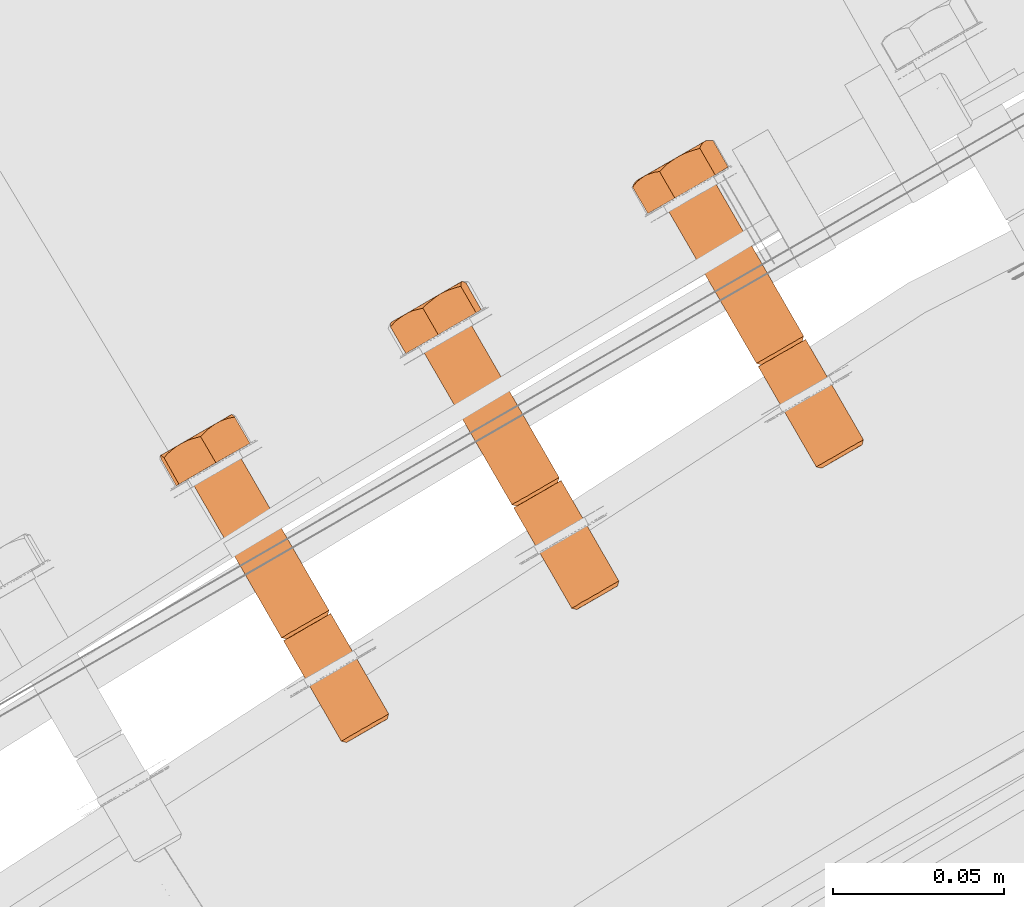
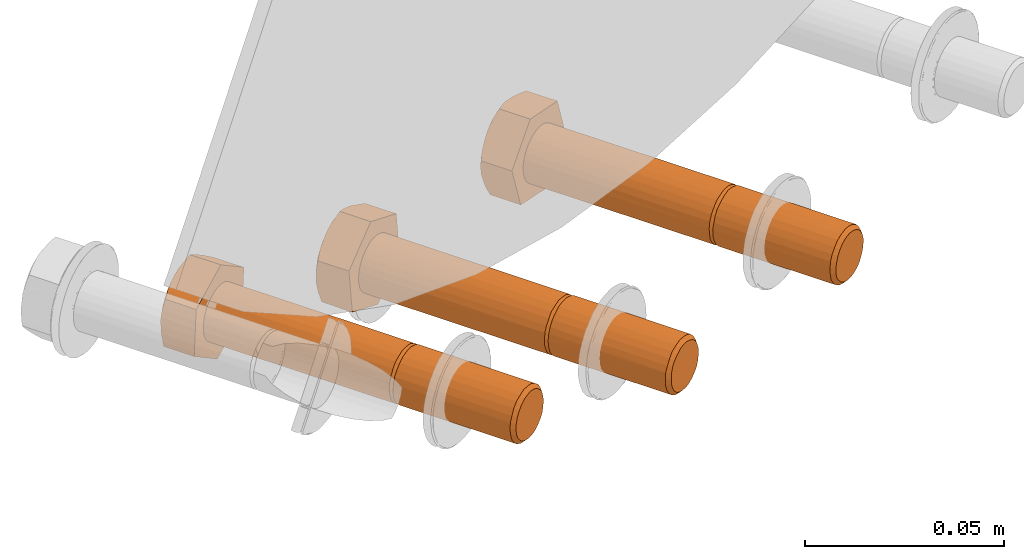
# One storey, part 75 of 126: 3 proxies.
"""IFC2X3 building model written with IfcOpenShell, lengths in millimetres."""

from ifc_helpers import new_model, si_unit, origin, origin_with_axes, place, context, project, spatial, faceted_brep, material, element, save


model = new_model("IFC2X3")

# Units and contexts
context_of_model_1 = context(None, 3, precision=0.1, world=origin())
context_of_model_2 = context(None, 3, precision=0.1, world=origin())
ifc_project = project(units=[si_unit("LENGTHUNIT", "METRE", prefix="MILLI"), si_unit("AREAUNIT", "SQUARE_METRE", prefix="CENTI"), si_unit("VOLUMEUNIT", "CUBIC_METRE", prefix="CENTI"), si_unit("MASSUNIT", "GRAM", prefix="KILO")], contexts=[context_of_model_1, context_of_model_2])

# Site, building, storey
site_placement = place(None, origin_with_axes())
site = spatial("IfcSite", under=ifc_project, at=site_placement, CompositionType="ELEMENT")
building_placement = place(site_placement, origin_with_axes())
building = spatial("IfcBuilding", under=site, at=building_placement, CompositionType="ELEMENT")
storey_placement = place(building_placement, origin_with_axes())
storey = spatial("IfcBuildingStorey", under=building, at=storey_placement, CompositionType="ELEMENT")

# Proxies
ifc_material = material(Name="STAHL")
proxy_1_placement = place(storey_placement, origin_with_axes())
element("IfcBuildingElementProxy", 1, at=proxy_1_placement, inside=storey, material=ifc_material, Name="profile", context=context_of_model_2, shape_type="Brep", body=[
    faceted_brep([(3989.7, 14868.7, 460.8), (3991.3, 14869.6, 460.2), (3992.0, 14868.8, 461.3), (3990.6, 14868.0, 461.8), (3988.3, 14867.9, 461.8), (3989.4, 14867.3, 462.7), (3987.1, 14867.2, 463.2), (3988.4, 14866.7, 463.9), (3986.2, 14866.7, 464.9), (3987.6, 14866.3, 465.3), (3985.8, 14866.4, 466.7), (3987.2, 14866.0, 466.9), (3985.7, 14866.4, 468.7), (3987.2, 14866.0, 468.6), (3986.0, 14866.6, 470.6), (3987.5, 14866.1, 470.2), (3986.7, 14867.0, 472.3), (3988.1, 14866.5, 471.7), (3987.8, 14867.6, 473.8), (3989.0, 14867.0, 473.0), (3989.1, 14868.4, 475.0), (3990.1, 14867.7, 474.0), (3990.6, 14869.2, 475.7), (3991.5, 14868.5, 474.7), (3992.3, 14870.2, 476.1), (3992.9, 14869.3, 475.0), (3994.0, 14871.2, 475.9), (3994.3, 14870.1, 474.9), (3972.2, 14899.0, 460.8), (3973.8, 14899.9, 460.2), (3974.5, 14899.1, 461.3), (3973.1, 14898.3, 461.8), (3970.8, 14898.2, 461.8), (3971.9, 14897.6, 462.7), (3969.6, 14897.5, 463.2), (3970.9, 14897.0, 463.9), (3968.7, 14897.0, 464.9), (3970.1, 14896.6, 465.3), (3968.3, 14896.7, 466.7), (3969.7, 14896.3, 466.9), (3968.2, 14896.7, 468.7), (3969.7, 14896.3, 468.6), (3968.5, 14896.9, 470.6), (3970.0, 14896.5, 470.2), (3969.2, 14897.3, 472.3), (3970.6, 14896.8, 471.7), (3970.3, 14897.9, 473.8), (3971.5, 14897.3, 473.0), (3971.6, 14898.7, 475.0), (3972.6, 14898.0, 474.0), (3973.1, 14899.5, 475.7), (3974.0, 14898.8, 474.7), (3974.8, 14900.5, 476.1), (3975.4, 14899.6, 475.0), (3976.5, 14901.5, 475.9), (3976.8, 14900.4, 474.9), (3995.5, 14872.1, 475.3), (3978.6, 14901.4, 475.3), (3977.0, 14900.5, 475.9), (3997.0, 14872.9, 474.3), (3980.0, 14902.3, 474.3), (3998.1, 14873.6, 472.9), (3981.2, 14902.9, 472.9), (3999.0, 14874.0, 471.2), (3982.0, 14903.4, 471.2), (3999.4, 14874.3, 469.4), (3982.5, 14903.7, 469.4), (3999.5, 14874.4, 467.5), (3982.6, 14903.7, 467.5), (3999.2, 14874.2, 465.6), (3982.2, 14903.5, 465.6), (3998.5, 14873.8, 463.8), (3981.5, 14903.1, 463.8), (3997.4, 14873.2, 462.3), (3980.5, 14902.5, 462.3), (3996.1, 14872.4, 461.2), (3979.1, 14901.8, 461.2), (3994.6, 14871.5, 460.4), (3977.6, 14900.9, 460.4), (3992.9, 14870.6, 460.1), (3976.0, 14899.9, 460.1), (3974.3, 14899.0, 460.2), (3947.8, 14947.2, 476.1), (3946.2, 14946.2, 475.7), (3949.5, 14948.2, 475.9), (3945.2, 14945.7, 460.8), (3946.8, 14946.6, 460.2), (3943.8, 14944.9, 461.8), (3942.6, 14944.2, 463.2), (3941.8, 14943.7, 464.9), (3941.3, 14943.4, 466.7), (3941.2, 14943.4, 468.7), (3941.6, 14943.6, 470.6), (3942.3, 14944.0, 472.3), (3943.3, 14944.6, 473.8), (3944.7, 14945.4, 475.0), (3978.0, 14902.4, 475.3), (3951.1, 14949.1, 475.3), (3979.5, 14903.2, 474.3), (3952.5, 14949.9, 474.3), (3980.6, 14903.9, 472.9), (3953.7, 14950.6, 472.9), (3981.5, 14904.4, 471.2), (3954.5, 14951.0, 471.2), (3981.9, 14904.6, 469.4), (3955.0, 14951.3, 469.4), (3982.0, 14904.7, 467.5), (3955.1, 14951.4, 467.5), (3981.7, 14904.5, 465.6), (3954.7, 14951.2, 465.6), (3981.0, 14904.1, 463.8), (3954.0, 14950.8, 463.8), (3979.9, 14903.5, 462.3), (3953.0, 14950.2, 462.3), (3978.6, 14902.7, 461.2), (3951.6, 14949.4, 461.2), (3977.1, 14901.8, 460.4), (3950.1, 14948.5, 460.4), (3975.4, 14900.9, 460.1), (3948.5, 14947.6, 460.1), (3936.4, 14940.6, 470.8), (3940.2, 14942.8, 457.7), (3952.0, 14949.6, 454.9), (3959.9, 14954.2, 465.4), (3956.1, 14951.9, 478.5), (3944.3, 14945.1, 481.2), (3955.5, 14961.9, 465.4), (3954.6, 14962.0, 467.3), (3953.9, 14962.0, 469.1), (3953.4, 14961.9, 470.5), (3953.0, 14961.7, 471.9), (3952.5, 14961.3, 473.7), (3952.1, 14960.8, 475.5), (3951.8, 14960.3, 477.0), (3951.6, 14959.7, 478.5), (3946.9, 14958.2, 479.3), (3947.9, 14958.5, 479.2), (3949.7, 14959.1, 478.9), (3952.3, 14961.3, 473.8), (3951.3, 14960.7, 475.6), (3950.0, 14960.0, 477.1), (3948.5, 14959.1, 478.3), (3946.5, 14957.9, 479.5), (3945.2, 14957.2, 479.8), (3951.0, 14960.5, 460.2), (3952.0, 14961.2, 461.8), (3952.8, 14961.6, 463.7), (3953.3, 14961.9, 465.7), (3953.5, 14962.0, 467.8), (3953.4, 14962.0, 469.9), (3954.3, 14961.7, 464.2), (3953.3, 14961.5, 463.0), (3952.1, 14961.1, 461.6), (3941.1, 14954.9, 456.3), (3942.9, 14955.9, 456.1), (3944.7, 14956.9, 456.2), (3946.5, 14958.0, 456.7), (3948.1, 14958.9, 457.5), (3949.7, 14959.8, 458.7), (3950.1, 14960.0, 459.0), (3949.3, 14959.4, 457.9), (3948.4, 14958.4, 456.4), (3947.5, 14957.3, 454.9), (3946.0, 14956.9, 455.3), (3944.5, 14956.4, 455.6), (3942.8, 14955.7, 455.9), (3943.6, 14956.2, 480.2), (3942.1, 14955.1, 480.6), (3941.0, 14954.0, 480.9), (3939.8, 14952.9, 481.2), (3938.4, 14952.7, 479.7), (3937.2, 14952.3, 478.3), (3936.2, 14952.0, 477.1), (3935.3, 14951.5, 476.0), (3934.3, 14950.8, 474.6), (3933.3, 14950.0, 473.1), (3932.6, 14949.2, 472.0), (3931.9, 14948.3, 470.8), (3933.3, 14950.4, 464.2), (3934.0, 14950.8, 462.3), (3935.0, 14951.4, 460.6), (3936.3, 14952.1, 459.0), (3937.8, 14952.9, 457.8), (3939.4, 14953.9, 456.9), (3939.9, 14954.1, 456.6), (3938.6, 14953.2, 456.9), (3937.2, 14951.9, 457.3), (3935.8, 14950.5, 457.7), (3935.1, 14950.6, 459.2), (3934.5, 14950.7, 460.6), (3933.9, 14950.6, 462.4), (3934.3, 14950.9, 474.3), (3933.5, 14950.4, 472.4), (3933.0, 14950.2, 470.4), (3932.8, 14950.0, 468.3), (3932.9, 14950.1, 466.2), (3932.9, 14950.1, 465.6), (3932.6, 14949.7, 467.1), (3932.2, 14949.1, 468.9), (3943.4, 14956.2, 480.1), (3941.6, 14955.1, 479.9), (3939.8, 14954.1, 479.4), (3938.2, 14953.2, 478.6), (3936.6, 14952.3, 477.4), (3968.7, 14895.8, 468.7), (3969.1, 14895.9, 470.6), (3969.8, 14896.4, 472.3), (3970.8, 14897.0, 473.8), (3972.2, 14897.7, 475.0), (3973.7, 14898.6, 475.7), (3975.3, 14899.6, 476.1), (3981.6, 14903.2, 467.5), (3981.6, 14903.2, 469.2), (3981.2, 14902.9, 470.8), (3980.4, 14902.5, 472.3), (3979.4, 14901.9, 473.5), (3978.2, 14901.2, 474.3), (3975.9, 14899.9, 461.2), (3977.3, 14900.7, 461.4), (3978.7, 14901.5, 462.1), (3979.8, 14902.2, 463.1), (3980.7, 14902.7, 464.4), (3981.3, 14903.0, 465.9), (3972.7, 14898.0, 460.8), (3971.3, 14897.2, 461.8), (3970.1, 14896.6, 463.2), (3969.3, 14896.1, 464.9), (3968.8, 14895.8, 466.7), (3993.4, 14869.6, 461.2), (3994.8, 14870.4, 461.4), (3996.2, 14871.2, 462.1), (3997.3, 14871.8, 463.1), (3998.2, 14872.4, 464.4), (3998.8, 14872.7, 465.9), (3999.1, 14872.9, 467.5), (3999.1, 14872.8, 469.2), (3998.7, 14872.6, 470.8), (3997.9, 14872.2, 472.3), (3996.9, 14871.6, 473.5), (3995.7, 14870.9, 474.3)], [[[0, 1, 2, 3]], [[4, 0, 3, 5]], [[6, 4, 5, 7]], [[8, 6, 7, 9]], [[10, 8, 9, 11]], [[12, 10, 11, 13]], [[14, 12, 13, 15]], [[16, 14, 15, 17]], [[18, 16, 17, 19]], [[20, 18, 19, 21]], [[22, 20, 21, 23]], [[24, 22, 23, 25]], [[26, 24, 25, 27]], [[28, 29, 30, 31]], [[32, 28, 31, 33]], [[34, 32, 33, 35]], [[36, 34, 35, 37]], [[38, 36, 37, 39]], [[40, 38, 39, 41]], [[42, 40, 41, 43]], [[44, 42, 43, 45]], [[46, 44, 45, 47]], [[48, 46, 47, 49]], [[50, 48, 49, 51]], [[52, 50, 51, 53]], [[54, 52, 53, 55]], [[26, 56, 57, 58]], [[56, 59, 60, 57]], [[59, 61, 62, 60]], [[61, 63, 64, 62]], [[63, 65, 66, 64]], [[65, 67, 68, 66]], [[67, 69, 70, 68]], [[69, 71, 72, 70]], [[71, 73, 74, 72]], [[73, 75, 76, 74]], [[75, 77, 78, 76]], [[77, 79, 80, 78]], [[1, 81, 80, 79]], [[52, 82, 83, 50]], [[54, 84, 82, 52]], [[29, 28, 85, 86]], [[32, 87, 85, 28]], [[34, 88, 87, 32]], [[36, 89, 88, 34]], [[38, 90, 89, 36]], [[40, 91, 90, 38]], [[42, 92, 91, 40]], [[44, 93, 92, 42]], [[46, 94, 93, 44]], [[48, 95, 94, 46]], [[50, 83, 95, 48]], [[54, 96, 97, 84]], [[96, 98, 99, 97]], [[98, 100, 101, 99]], [[100, 102, 103, 101]], [[102, 104, 105, 103]], [[104, 106, 107, 105]], [[106, 108, 109, 107]], [[108, 110, 111, 109]], [[110, 112, 113, 111]], [[112, 114, 115, 113]], [[114, 116, 117, 115]], [[116, 118, 119, 117]], [[29, 86, 119, 118]], [[120, 121, 89, 90, 91, 92, 93, 94, 95, 83, 82, 84, 97, 99, 101, 103, 105, 107, 109, 111, 113, 115, 117, 119, 86, 85, 87, 88, 89, 121, 122, 123, 124, 125]], [[124, 123, 126, 127, 128, 129, 130, 131, 132, 133, 134]], [[135, 136, 137, 134, 133, 132, 131, 130, 138, 139, 140, 141]], [[142, 136, 135]], [[143, 142, 135]], [[144, 145, 146, 147, 148, 149, 129, 128, 127, 126, 150, 151, 152]], [[130, 129, 149]], [[153, 154, 155, 156, 157, 158, 159, 160, 161, 162, 163, 164, 165]], [[144, 159, 158]], [[125, 124, 134, 137, 136, 142, 143, 166, 167, 168, 169]], [[120, 125, 169, 170, 171, 172, 173, 174, 175, 176, 177]], [[178, 179, 180, 181, 182, 183, 184, 185, 186, 187, 188, 189, 190]], [[153, 184, 183]], [[177, 176, 175, 174, 173, 191, 192, 193, 194, 195, 196, 197, 198]], [[178, 196, 195]], [[172, 171, 170, 169, 168, 167, 166, 143, 199, 200, 201, 202, 203]], [[173, 172, 203]], [[120, 177, 198, 197, 196, 178, 190, 189, 188, 187, 121]], [[121, 187, 186, 185, 184, 153, 165, 164, 163, 162, 122]], [[122, 162, 161, 160, 159, 144, 152, 151, 150, 126, 123]], [[194, 193, 192, 191, 173, 203, 202, 201, 200, 199, 143, 135, 141, 140, 139, 138, 130, 149, 148, 147, 146, 145, 144, 158, 157, 156, 155, 154, 153, 183, 182, 181, 180, 179, 178, 195]], [[204, 205, 206, 207, 208, 209, 210, 58, 57, 60, 62, 64, 66, 211, 212, 213, 214, 215, 216, 55, 53, 51, 49, 47, 45, 43, 41, 39, 37, 35, 33, 31, 30, 217, 218, 219, 220, 221, 222, 211, 66, 68, 70, 72, 74, 76, 78, 80, 81, 223, 224, 225, 226, 227]], [[96, 54, 55, 216]], [[98, 96, 216, 215]], [[100, 98, 215, 214]], [[102, 100, 214, 213]], [[104, 102, 213, 212]], [[106, 104, 212, 211]], [[108, 106, 211, 222]], [[110, 108, 222, 221]], [[112, 110, 221, 220]], [[114, 112, 220, 219]], [[116, 114, 219, 218]], [[118, 116, 218, 217]], [[30, 29, 118, 217]], [[26, 58, 210, 24]], [[0, 223, 81, 1]], [[4, 224, 223, 0]], [[6, 225, 224, 4]], [[8, 226, 225, 6]], [[10, 227, 226, 8]], [[12, 204, 227, 10]], [[14, 205, 204, 12]], [[16, 206, 205, 14]], [[18, 207, 206, 16]], [[20, 208, 207, 18]], [[22, 209, 208, 20]], [[24, 210, 209, 22]], [[13, 11, 9, 7, 5, 3, 2, 228, 229, 230, 231, 232, 233, 234, 235, 236, 237, 238, 239, 27, 25, 23, 21, 19, 17, 15]], [[56, 26, 27, 239]], [[59, 56, 239, 238]], [[61, 59, 238, 237]], [[63, 61, 237, 236]], [[65, 63, 236, 235]], [[67, 65, 235, 234]], [[69, 67, 234, 233]], [[71, 69, 233, 232]], [[73, 71, 232, 231]], [[75, 73, 231, 230]], [[77, 75, 230, 229]], [[79, 77, 229, 228]], [[1, 79, 228, 2]]]),
])
proxy_2_placement = place(storey_placement, origin_with_axes())
element("IfcBuildingElementProxy", 2, at=proxy_2_placement, inside=storey, material=ifc_material, Name="profile", context=context_of_model_2, shape_type="Brep", body=[
    faceted_brep([(3918.0, 14826.0, 478.9), (3916.9, 14826.7, 478.1), (3918.4, 14827.5, 477.1), (3919.3, 14826.8, 478.1), (3916.9, 14825.4, 480.1), (3915.7, 14826.0, 479.4), (3916.2, 14825.0, 481.5), (3914.8, 14825.4, 481.0), (3915.7, 14824.7, 483.1), (3914.2, 14825.1, 482.8), (3915.6, 14824.6, 484.7), (3914.1, 14825.0, 484.8), (3915.8, 14824.8, 486.4), (3914.3, 14825.2, 486.7), (3916.3, 14825.1, 487.9), (3915.0, 14825.5, 488.4), (3917.2, 14825.6, 489.3), (3916.0, 14826.1, 490.0), (3918.3, 14826.2, 490.3), (3917.2, 14826.9, 491.2), (3919.6, 14827.0, 491.1), (3918.8, 14827.7, 492.1), (3921.0, 14827.8, 491.4), (3920.4, 14828.7, 492.5), (3922.5, 14828.6, 491.4), (3922.1, 14829.6, 492.4), (3923.8, 14829.4, 490.9), (3923.7, 14830.6, 491.9), (3900.5, 14856.4, 478.9), (3899.4, 14857.0, 478.1), (3900.9, 14857.8, 477.1), (3901.8, 14857.1, 478.1), (3899.4, 14855.8, 480.1), (3898.2, 14856.3, 479.4), (3898.7, 14855.3, 481.5), (3897.3, 14855.7, 481.0), (3898.2, 14855.0, 483.1), (3896.7, 14855.4, 482.8), (3898.1, 14854.9, 484.7), (3896.6, 14855.3, 484.8), (3898.3, 14855.1, 486.4), (3896.8, 14855.5, 486.7), (3898.8, 14855.4, 487.9), (3897.5, 14855.9, 488.4), (3899.7, 14855.9, 489.3), (3898.5, 14856.4, 490.0), (3900.8, 14856.5, 490.3), (3899.7, 14857.2, 491.2), (3902.1, 14857.3, 491.1), (3901.3, 14858.0, 492.1), (3903.5, 14858.1, 491.4), (3902.9, 14859.0, 492.5), (3905.0, 14858.9, 491.4), (3904.6, 14859.9, 492.4), (3906.3, 14859.7, 490.9), (3906.2, 14860.9, 491.9), (3901.4, 14856.9, 477.1), (3903.0, 14857.8, 476.6), (3920.0, 14828.4, 476.6), (3925.1, 14831.4, 491.0), (3908.2, 14860.8, 491.0), (3906.7, 14859.9, 491.9), (3926.3, 14832.1, 489.6), (3909.4, 14861.5, 489.6), (3927.2, 14832.6, 488.0), (3910.3, 14862.0, 488.0), (3927.8, 14832.9, 486.2), (3910.8, 14862.3, 486.2), (3927.9, 14833.0, 484.3), (3911.0, 14862.4, 484.3), (3927.7, 14832.9, 482.4), (3910.7, 14862.3, 482.4), (3927.0, 14832.5, 480.6), (3910.1, 14861.9, 480.6), (3926.1, 14831.9, 479.0), (3909.1, 14861.3, 479.0), (3924.8, 14831.2, 477.8), (3907.8, 14860.6, 477.8), (3923.3, 14830.3, 477.0), (3906.3, 14859.7, 477.0), (3921.6, 14829.4, 476.5), (3904.7, 14858.8, 476.5), (3877.6, 14906.6, 492.4), (3875.9, 14905.7, 492.5), (3879.2, 14907.6, 491.9), (3872.4, 14903.7, 478.1), (3873.9, 14904.5, 477.1), (3871.2, 14903.0, 479.4), (3870.3, 14902.4, 481.0), (3869.8, 14902.1, 482.8), (3869.6, 14902.0, 484.8), (3869.9, 14902.2, 486.7), (3870.5, 14902.6, 488.4), (3871.5, 14903.1, 490.0), (3872.8, 14903.9, 491.2), (3874.3, 14904.7, 492.1), (3907.6, 14861.7, 491.0), (3880.7, 14908.4, 491.0), (3908.8, 14862.4, 489.6), (3881.9, 14909.1, 489.6), (3909.7, 14862.9, 488.0), (3882.8, 14909.6, 488.0), (3910.3, 14863.3, 486.2), (3883.3, 14910.0, 486.2), (3910.4, 14863.3, 484.3), (3883.5, 14910.0, 484.3), (3910.2, 14863.2, 482.4), (3883.2, 14909.9, 482.4), (3909.5, 14862.8, 480.6), (3882.6, 14909.5, 480.6), (3908.6, 14862.3, 479.0), (3881.6, 14909.0, 479.0), (3907.3, 14861.5, 477.8), (3880.3, 14908.2, 477.8), (3905.8, 14860.6, 477.0), (3878.8, 14907.3, 477.0), (3904.1, 14859.7, 476.5), (3877.2, 14906.4, 476.5), (3902.5, 14858.7, 476.6), (3875.5, 14905.4, 476.6), (3865.5, 14899.6, 489.8), (3867.0, 14900.5, 476.1), (3878.1, 14906.9, 470.8), (3887.6, 14912.4, 479.2), (3886.1, 14911.5, 493.0), (3875.0, 14905.1, 498.3), (3883.2, 14920.2, 479.2), (3882.7, 14920.5, 481.2), (3882.3, 14920.7, 483.1), (3882.1, 14920.7, 484.6), (3881.9, 14920.6, 486.1), (3881.7, 14920.5, 488.0), (3881.6, 14920.1, 489.8), (3881.6, 14919.7, 491.4), (3881.6, 14919.3, 493.0), (3877.1, 14917.9, 494.6), (3878.1, 14918.2, 494.4), (3879.8, 14918.8, 493.7), (3881.5, 14920.4, 488.1), (3880.8, 14920.0, 490.1), (3879.8, 14919.5, 491.8), (3878.6, 14918.8, 493.4), (3876.8, 14917.7, 495.0), (3875.5, 14917.0, 495.6), (3877.9, 14918.4, 475.0), (3879.2, 14919.1, 476.4), (3880.3, 14919.8, 478.1), (3881.2, 14920.2, 479.9), (3881.7, 14920.6, 481.9), (3881.9, 14920.7, 484.0), (3881.9, 14919.9, 478.2), (3880.6, 14919.6, 477.3), (3879.2, 14919.0, 476.1), (3867.6, 14912.4, 473.4), (3869.3, 14913.4, 472.8), (3871.1, 14914.4, 472.5), (3872.9, 14915.5, 472.6), (3874.7, 14916.5, 473.1), (3876.3, 14917.5, 473.9), (3876.9, 14917.7, 474.1), (3875.9, 14917.0, 473.2), (3874.8, 14915.9, 472.0), (3873.7, 14914.7, 470.8), (3872.2, 14914.3, 471.4), (3870.8, 14913.9, 472.0), (3869.1, 14913.2, 472.7), (3874.1, 14916.0, 496.3), (3872.7, 14914.9, 497.1), (3871.6, 14914.0, 497.6), (3870.5, 14912.9, 498.3), (3868.9, 14912.5, 497.0), (3867.4, 14912.1, 495.9), (3866.3, 14911.6, 495.0), (3865.2, 14911.0, 494.0), (3864.0, 14910.2, 492.9), (3862.8, 14909.3, 491.7), (3861.9, 14908.4, 490.8), (3861.0, 14907.4, 489.8), (3862.6, 14908.3, 476.1), (3862.2, 14908.5, 477.7), (3861.8, 14908.7, 479.2), (3861.5, 14908.8, 481.1), (3861.2, 14908.8, 482.9), (3861.6, 14909.0, 480.9), (3862.3, 14909.4, 479.0), (3863.3, 14909.9, 477.2), (3864.5, 14910.6, 475.7), (3866.0, 14911.5, 474.4), (3866.4, 14911.7, 474.0), (3865.2, 14910.8, 474.6), (3863.9, 14909.6, 475.3), (3863.9, 14910.3, 492.6), (3862.8, 14909.6, 491.0), (3861.9, 14909.2, 489.1), (3861.4, 14908.8, 487.1), (3861.2, 14908.7, 485.0), (3861.1, 14908.6, 484.4), (3861.0, 14908.4, 485.9), (3861.0, 14907.9, 487.8), (3873.8, 14916.0, 496.2), (3872.0, 14915.0, 496.5), (3870.2, 14913.9, 496.4), (3868.4, 14912.9, 496.0), (3866.8, 14911.9, 495.2), (3897.1, 14854.4, 484.8), (3897.4, 14854.6, 486.7), (3898.0, 14854.9, 488.4), (3899.0, 14855.5, 490.0), (3900.3, 14856.2, 491.2), (3901.8, 14857.1, 492.1), (3903.4, 14858.0, 492.5), (3905.1, 14859.0, 492.4), (3909.8, 14861.7, 482.7), (3910.0, 14861.9, 484.3), (3909.9, 14861.8, 486.0), (3909.4, 14861.5, 487.5), (3908.7, 14861.1, 488.9), (3907.6, 14860.5, 490.1), (3903.1, 14857.9, 477.7), (3904.6, 14858.7, 477.6), (3906.0, 14859.5, 478.0), (3907.3, 14860.3, 478.7), (3908.4, 14860.9, 479.8), (3909.3, 14861.4, 481.1), (3899.9, 14856.0, 478.1), (3898.7, 14855.3, 479.4), (3897.8, 14854.8, 481.0), (3897.3, 14854.5, 482.8), (3920.6, 14827.6, 477.7), (3922.1, 14828.4, 477.6), (3923.5, 14829.2, 478.0), (3924.8, 14830.0, 478.7), (3925.9, 14830.6, 479.8), (3926.8, 14831.1, 481.1), (3927.3, 14831.4, 482.7), (3927.5, 14831.6, 484.3), (3927.4, 14831.5, 486.0), (3926.9, 14831.2, 487.5), (3926.2, 14830.8, 488.9), (3925.1, 14830.1, 490.1)], [[[0, 1, 2, 3]], [[4, 5, 1, 0]], [[6, 7, 5, 4]], [[8, 9, 7, 6]], [[10, 11, 9, 8]], [[12, 13, 11, 10]], [[14, 15, 13, 12]], [[16, 17, 15, 14]], [[18, 19, 17, 16]], [[20, 21, 19, 18]], [[22, 23, 21, 20]], [[24, 25, 23, 22]], [[26, 27, 25, 24]], [[28, 29, 30, 31]], [[32, 33, 29, 28]], [[34, 35, 33, 32]], [[36, 37, 35, 34]], [[38, 39, 37, 36]], [[40, 41, 39, 38]], [[42, 43, 41, 40]], [[44, 45, 43, 42]], [[46, 47, 45, 44]], [[48, 49, 47, 46]], [[50, 51, 49, 48]], [[52, 53, 51, 50]], [[54, 55, 53, 52]], [[2, 56, 57, 58]], [[59, 60, 61, 27]], [[62, 63, 60, 59]], [[64, 65, 63, 62]], [[66, 67, 65, 64]], [[68, 69, 67, 66]], [[70, 71, 69, 68]], [[72, 73, 71, 70]], [[74, 75, 73, 72]], [[76, 77, 75, 74]], [[78, 79, 77, 76]], [[80, 81, 79, 78]], [[58, 57, 81, 80]], [[53, 82, 83, 51]], [[55, 84, 82, 53]], [[29, 85, 86, 30]], [[33, 87, 85, 29]], [[35, 88, 87, 33]], [[37, 89, 88, 35]], [[39, 90, 89, 37]], [[41, 91, 90, 39]], [[43, 92, 91, 41]], [[45, 93, 92, 43]], [[47, 94, 93, 45]], [[49, 95, 94, 47]], [[51, 83, 95, 49]], [[96, 97, 84, 55]], [[96, 98, 99, 97]], [[98, 100, 101, 99]], [[100, 102, 103, 101]], [[102, 104, 105, 103]], [[104, 106, 107, 105]], [[106, 108, 109, 107]], [[108, 110, 111, 109]], [[110, 112, 113, 111]], [[112, 114, 115, 113]], [[114, 116, 117, 115]], [[116, 118, 119, 117]], [[118, 30, 86, 119]], [[120, 121, 89, 90, 91, 92, 93, 94, 95, 83, 82, 84, 97, 99, 101, 103, 105, 107, 109, 111, 113, 115, 117, 119, 86, 85, 87, 88, 89, 121, 122, 123, 124, 125]], [[124, 123, 126, 127, 128, 129, 130, 131, 132, 133, 134]], [[135, 136, 137, 134, 133, 132, 131, 130, 138, 139, 140, 141]], [[142, 136, 135]], [[143, 142, 135]], [[144, 145, 146, 147, 148, 149, 129, 128, 127, 126, 150, 151, 152]], [[130, 129, 149]], [[153, 154, 155, 156, 157, 158, 159, 160, 161, 162, 163, 164, 165]], [[144, 159, 158]], [[125, 124, 134, 137, 136, 142, 143, 166, 167, 168, 169]], [[120, 125, 169, 170, 171, 172, 173, 174, 175, 176, 177]], [[178, 179, 180, 181, 182, 183, 184, 185, 186, 187, 188, 189, 190]], [[153, 188, 187]], [[177, 176, 175, 174, 173, 191, 192, 193, 194, 195, 196, 197, 198]], [[182, 196, 195]], [[172, 171, 170, 169, 168, 167, 166, 143, 199, 200, 201, 202, 203]], [[173, 172, 203]], [[120, 177, 198, 197, 196, 182, 181, 180, 179, 178, 121]], [[121, 178, 190, 189, 188, 153, 165, 164, 163, 162, 122]], [[122, 162, 161, 160, 159, 144, 152, 151, 150, 126, 123]], [[195, 194, 193, 192, 191, 173, 203, 202, 201, 200, 199, 143, 135, 141, 140, 139, 138, 130, 149, 148, 147, 146, 145, 144, 158, 157, 156, 155, 154, 153, 187, 186, 185, 184, 183, 182]], [[204, 205, 206, 207, 208, 209, 210, 211, 61, 60, 63, 65, 67, 69, 212, 213, 214, 215, 216, 217, 54, 52, 50, 48, 46, 44, 42, 40, 38, 36, 34, 32, 28, 31, 218, 219, 220, 221, 222, 223, 212, 69, 71, 73, 75, 77, 79, 81, 57, 56, 224, 225, 226, 227]], [[217, 96, 55, 54]], [[216, 98, 96, 217]], [[215, 100, 98, 216]], [[214, 102, 100, 215]], [[213, 104, 102, 214]], [[212, 106, 104, 213]], [[223, 108, 106, 212]], [[222, 110, 108, 223]], [[221, 112, 110, 222]], [[220, 114, 112, 221]], [[219, 116, 114, 220]], [[218, 118, 116, 219]], [[30, 118, 218, 31]], [[1, 224, 56, 2]], [[1, 5, 225, 224]], [[5, 7, 226, 225]], [[7, 9, 227, 226]], [[9, 11, 204, 227]], [[11, 13, 205, 204]], [[13, 15, 206, 205]], [[15, 17, 207, 206]], [[17, 19, 208, 207]], [[19, 21, 209, 208]], [[21, 23, 210, 209]], [[23, 25, 211, 210]], [[25, 27, 61, 211]], [[10, 8, 6, 4, 0, 3, 228, 229, 230, 231, 232, 233, 234, 235, 236, 237, 238, 239, 26, 24, 22, 20, 18, 16, 14, 12]], [[239, 59, 27, 26]], [[238, 62, 59, 239]], [[237, 64, 62, 238]], [[236, 66, 64, 237]], [[235, 68, 66, 236]], [[234, 70, 68, 235]], [[233, 72, 70, 234]], [[232, 74, 72, 233]], [[231, 76, 74, 232]], [[230, 78, 76, 231]], [[229, 80, 78, 230]], [[228, 58, 80, 229]], [[2, 58, 228, 3]]]),
])
proxy_3_placement = place(storey_placement, origin_with_axes())
element("IfcBuildingElementProxy", 3, at=proxy_3_placement, inside=storey, material=ifc_material, Name="profile", context=context_of_model_2, shape_type="Brep", body=[
    faceted_brep([(3849.7, 14786.6, 512.1), (3848.4, 14787.1, 511.4), (3849.7, 14787.9, 510.1), (3850.8, 14787.2, 511.0), (3848.8, 14786.1, 513.5), (3847.5, 14786.6, 512.9), (3848.3, 14785.8, 515.0), (3846.9, 14786.2, 514.7), (3848.1, 14785.7, 516.7), (3846.6, 14786.1, 516.7), (3848.3, 14785.8, 518.3), (3846.8, 14786.2, 518.6), (3848.8, 14786.1, 519.9), (3847.4, 14786.5, 520.4), (3849.6, 14786.5, 521.3), (3848.3, 14787.1, 522.0), (3850.6, 14787.1, 522.4), (3849.5, 14787.8, 523.3), (3851.9, 14787.9, 523.2), (3851.0, 14788.6, 524.2), (3853.3, 14788.7, 523.6), (3852.6, 14789.6, 524.7), (3854.7, 14789.5, 523.7), (3854.3, 14790.5, 524.7), (3856.1, 14790.3, 523.3), (3855.9, 14791.5, 524.3), (3857.4, 14791.1, 522.5), (3857.4, 14792.3, 523.4), (3832.2, 14816.9, 512.1), (3830.9, 14817.5, 511.4), (3832.2, 14818.2, 510.1), (3833.3, 14817.5, 511.0), (3831.3, 14816.4, 513.5), (3830.0, 14816.9, 512.9), (3830.8, 14816.1, 515.0), (3829.4, 14816.5, 514.7), (3830.6, 14816.0, 516.7), (3829.1, 14816.4, 516.7), (3830.8, 14816.1, 518.3), (3829.3, 14816.5, 518.6), (3831.3, 14816.4, 519.9), (3829.9, 14816.8, 520.4), (3832.1, 14816.8, 521.3), (3830.8, 14817.4, 522.0), (3833.1, 14817.5, 522.4), (3832.0, 14818.1, 523.3), (3834.4, 14818.2, 523.2), (3833.5, 14818.9, 524.2), (3835.8, 14819.0, 523.6), (3835.1, 14819.9, 524.7), (3837.2, 14819.8, 523.7), (3836.8, 14820.8, 524.7), (3838.6, 14820.6, 523.3), (3838.4, 14821.8, 524.3), (3839.9, 14821.4, 522.5), (3839.9, 14822.6, 523.4), (3858.7, 14793.0, 522.2), (3841.7, 14822.4, 522.2), (3840.5, 14821.7, 523.4), (3859.7, 14793.6, 520.6), (3842.7, 14823.0, 520.6), (3860.3, 14794.0, 518.8), (3843.3, 14823.3, 518.8), (3860.5, 14794.1, 516.9), (3843.5, 14823.5, 516.9), (3860.3, 14794.0, 515.0), (3843.4, 14823.4, 515.0), (3859.7, 14793.7, 513.2), (3842.8, 14823.0, 513.2), (3858.8, 14793.1, 511.6), (3841.9, 14822.5, 511.6), (3857.6, 14792.4, 510.3), (3840.6, 14821.8, 510.3), (3856.1, 14791.6, 509.3), (3839.2, 14820.9, 509.3), (3854.5, 14790.6, 508.8), (3837.5, 14820.0, 508.8), (3852.8, 14789.7, 508.8), (3835.9, 14819.0, 508.8), (3851.2, 14788.7, 509.3), (3834.2, 14818.1, 509.3), (3832.8, 14817.2, 510.1), (3811.5, 14868.5, 524.3), (3809.8, 14867.5, 524.7), (3813.0, 14869.3, 523.4), (3804.0, 14864.1, 511.4), (3805.3, 14864.9, 510.1), (3803.0, 14863.6, 512.9), (3802.4, 14863.2, 514.7), (3802.2, 14863.1, 516.7), (3802.4, 14863.2, 518.6), (3802.9, 14863.5, 520.4), (3803.9, 14864.1, 522.0), (3805.1, 14864.8, 523.3), (3806.6, 14865.6, 524.2), (3808.2, 14866.6, 524.7), (3841.2, 14823.4, 522.2), (3814.2, 14870.1, 522.2), (3842.2, 14823.9, 520.6), (3815.2, 14870.6, 520.6), (3842.8, 14824.3, 518.8), (3815.8, 14871.0, 518.8), (3843.0, 14824.4, 516.9), (3816.0, 14871.1, 516.9), (3842.8, 14824.3, 515.0), (3815.9, 14871.0, 515.0), (3842.2, 14824.0, 513.2), (3815.3, 14870.7, 513.2), (3841.3, 14823.4, 511.6), (3814.4, 14870.1, 511.6), (3840.1, 14822.7, 510.3), (3813.1, 14869.4, 510.3), (3838.6, 14821.9, 509.3), (3811.7, 14868.6, 509.3), (3837.0, 14820.9, 508.8), (3810.0, 14867.6, 508.8), (3835.3, 14820.0, 508.8), (3808.4, 14866.7, 508.8), (3833.7, 14819.0, 509.3), (3806.7, 14865.7, 509.3), (3798.3, 14860.9, 510.6), (3808.3, 14866.6, 502.9), (3819.1, 14872.9, 509.1), (3819.9, 14873.3, 522.9), (3809.9, 14867.6, 530.6), (3799.1, 14861.3, 524.5), (3814.6, 14880.6, 509.1), (3814.5, 14881.1, 511.1), (3814.4, 14881.5, 513.0), (3814.4, 14881.7, 514.5), (3814.5, 14881.7, 516.0), (3814.6, 14881.7, 517.9), (3814.9, 14881.6, 519.8), (3815.1, 14881.4, 521.3), (3815.4, 14881.0, 522.9), (3811.0, 14879.7, 525.9), (3812.2, 14880.2, 525.1), (3813.7, 14880.7, 524.0), (3814.4, 14881.7, 518.1), (3814.1, 14881.5, 520.1), (3813.4, 14881.1, 522.1), (3812.5, 14880.6, 523.9), (3811.3, 14879.9, 525.4), (3809.9, 14879.1, 526.8), (3808.7, 14878.4, 506.0), (3810.3, 14879.3, 507.1), (3811.6, 14880.1, 508.5), (3812.7, 14880.7, 510.1), (3813.6, 14881.3, 511.9), (3814.2, 14881.6, 513.9), (3813.2, 14880.2, 508.4), (3811.8, 14879.8, 507.7), (3810.2, 14879.2, 506.8), (3798.3, 14872.4, 506.8), (3799.9, 14873.3, 505.8), (3801.6, 14874.3, 505.1), (3803.4, 14875.4, 504.8), (3805.2, 14876.4, 504.8), (3807.0, 14877.4, 505.3), (3807.6, 14877.7, 505.3), (3806.5, 14876.9, 504.7), (3805.2, 14875.7, 503.8), (3803.9, 14874.4, 502.9), (3802.5, 14874.1, 503.8), (3801.2, 14873.7, 504.7), (3799.7, 14873.1, 505.7), (3808.6, 14878.2, 527.8), (3807.3, 14877.2, 528.9), (3806.4, 14876.3, 529.7), (3805.4, 14875.3, 530.6), (3803.6, 14874.8, 529.7), (3802.0, 14874.3, 528.9), (3800.7, 14873.7, 528.2), (3799.5, 14873.1, 527.5), (3798.1, 14872.2, 526.7), (3796.7, 14871.1, 525.9), (3795.7, 14870.2, 525.2), (3794.7, 14869.1, 524.5), (3793.9, 14868.6, 510.6), (3793.8, 14869.0, 512.2), (3793.7, 14869.4, 513.8), (3793.7, 14869.6, 515.7), (3793.7, 14869.8, 517.6), (3793.8, 14869.8, 515.5), (3794.1, 14870.0, 513.4), (3794.8, 14870.4, 511.5), (3795.7, 14870.9, 509.7), (3796.9, 14871.6, 508.1), (3797.3, 14871.7, 507.6), (3796.3, 14871.0, 508.5), (3795.0, 14869.9, 509.5), (3798.0, 14872.2, 526.5), (3796.6, 14871.4, 525.1), (3795.5, 14870.8, 523.4), (3794.6, 14870.3, 521.6), (3794.0, 14869.9, 519.6), (3794.0, 14869.7, 520.6), (3794.3, 14869.4, 522.5), (3793.8, 14869.8, 519.1), (3808.3, 14878.2, 527.8), (3806.6, 14877.2, 528.4), (3804.8, 14876.2, 528.7), (3803.0, 14875.1, 528.7), (3801.2, 14874.1, 528.3), (3829.7, 14815.5, 516.7), (3829.9, 14815.6, 518.6), (3830.4, 14815.9, 520.4), (3831.4, 14816.4, 522.0), (3832.6, 14817.1, 523.3), (3834.1, 14818.0, 524.2), (3835.7, 14818.9, 524.7), (3837.3, 14819.9, 524.7), (3839.0, 14820.8, 524.3), (3842.0, 14822.6, 513.7), (3842.4, 14822.8, 515.2), (3842.6, 14822.9, 516.9), (3842.4, 14822.8, 518.5), (3841.9, 14822.5, 520.1), (3841.0, 14822.0, 521.4), (3834.6, 14818.3, 510.3), (3836.0, 14819.1, 509.9), (3837.4, 14819.9, 509.9), (3838.8, 14820.7, 510.3), (3840.1, 14821.5, 511.1), (3841.2, 14822.1, 512.3), (3831.5, 14816.5, 511.4), (3830.5, 14816.0, 512.9), (3829.9, 14815.6, 514.7), (3852.1, 14788.0, 510.3), (3853.5, 14788.8, 509.9), (3854.9, 14789.6, 509.9), (3856.3, 14790.4, 510.3), (3857.6, 14791.2, 511.1), (3858.7, 14791.8, 512.3), (3859.5, 14792.2, 513.7), (3859.9, 14792.5, 515.2), (3860.1, 14792.6, 516.9), (3859.9, 14792.5, 518.5), (3859.4, 14792.2, 520.1), (3858.5, 14791.7, 521.4)], [[[0, 1, 2, 3]], [[4, 5, 1, 0]], [[6, 7, 5, 4]], [[8, 9, 7, 6]], [[10, 11, 9, 8]], [[12, 13, 11, 10]], [[14, 15, 13, 12]], [[16, 17, 15, 14]], [[18, 19, 17, 16]], [[20, 21, 19, 18]], [[22, 23, 21, 20]], [[24, 25, 23, 22]], [[26, 27, 25, 24]], [[28, 29, 30, 31]], [[32, 33, 29, 28]], [[34, 35, 33, 32]], [[36, 37, 35, 34]], [[38, 39, 37, 36]], [[40, 41, 39, 38]], [[42, 43, 41, 40]], [[44, 45, 43, 42]], [[46, 47, 45, 44]], [[48, 49, 47, 46]], [[50, 51, 49, 48]], [[52, 53, 51, 50]], [[54, 55, 53, 52]], [[27, 56, 57, 58]], [[56, 59, 60, 57]], [[59, 61, 62, 60]], [[61, 63, 64, 62]], [[63, 65, 66, 64]], [[65, 67, 68, 66]], [[67, 69, 70, 68]], [[69, 71, 72, 70]], [[71, 73, 74, 72]], [[73, 75, 76, 74]], [[75, 77, 78, 76]], [[77, 79, 80, 78]], [[79, 2, 81, 80]], [[53, 82, 83, 51]], [[55, 84, 82, 53]], [[30, 29, 85, 86]], [[33, 87, 85, 29]], [[35, 88, 87, 33]], [[37, 89, 88, 35]], [[39, 90, 89, 37]], [[41, 91, 90, 39]], [[43, 92, 91, 41]], [[45, 93, 92, 43]], [[47, 94, 93, 45]], [[49, 95, 94, 47]], [[51, 83, 95, 49]], [[55, 96, 97, 84]], [[96, 98, 99, 97]], [[98, 100, 101, 99]], [[100, 102, 103, 101]], [[102, 104, 105, 103]], [[104, 106, 107, 105]], [[106, 108, 109, 107]], [[108, 110, 111, 109]], [[110, 112, 113, 111]], [[112, 114, 115, 113]], [[114, 116, 117, 115]], [[116, 118, 119, 117]], [[30, 86, 119, 118]], [[120, 121, 122, 123, 124, 125, 120, 89, 90, 91, 92, 93, 94, 95, 83, 82, 84, 97, 99, 101, 103, 105, 107, 109, 111, 113, 115, 117, 119, 86, 85, 87, 88, 89]], [[122, 126, 127, 128, 129, 130, 131, 132, 133, 134, 123]], [[135, 136, 137, 134, 133, 132, 131, 130, 138, 139, 140, 141, 142]], [[143, 135, 142]], [[144, 145, 146, 147, 148, 149, 128, 127, 126, 150, 151, 152]], [[129, 128, 149]], [[130, 129, 149]], [[153, 154, 155, 156, 157, 158, 159, 160, 161, 162, 163, 164, 165]], [[144, 159, 158]], [[124, 123, 134, 137, 136, 135, 143, 166, 167, 168, 169]], [[125, 124, 169, 170, 171, 172, 173, 174, 175, 176, 177]], [[178, 179, 180, 181, 182, 183, 184, 185, 186, 187, 188, 189, 190]], [[153, 188, 187]], [[177, 176, 175, 174, 173, 191, 192, 193, 194, 195, 196, 197]], [[198, 196, 195]], [[182, 198, 195]], [[172, 171, 170, 169, 168, 167, 166, 143, 199, 200, 201, 202, 203]], [[173, 172, 203]], [[120, 125, 177, 197, 196, 198, 182, 181, 180, 179, 178]], [[120, 178, 190, 189, 188, 153, 165, 164, 163, 162, 121]], [[121, 162, 161, 160, 159, 144, 152, 151, 150, 126, 122]], [[182, 195, 194, 193, 192, 191, 173, 203, 202, 201, 200, 199, 143, 142, 141, 140, 139, 138, 130, 149, 148, 147, 146, 145, 144, 158, 157, 156, 155, 154, 153, 187, 186, 185, 184, 183]], [[204, 205, 206, 207, 208, 209, 210, 211, 212, 58, 57, 60, 62, 64, 66, 213, 214, 215, 216, 217, 218, 54, 52, 50, 48, 46, 44, 42, 40, 38, 36, 34, 32, 28, 31, 219, 220, 221, 222, 223, 224, 213, 66, 68, 70, 72, 74, 76, 78, 80, 81, 225, 226, 227]], [[96, 55, 54, 218]], [[98, 96, 218, 217]], [[100, 98, 217, 216]], [[102, 100, 216, 215]], [[104, 102, 215, 214]], [[106, 104, 214, 213]], [[108, 106, 213, 224]], [[110, 108, 224, 223]], [[112, 110, 223, 222]], [[114, 112, 222, 221]], [[116, 114, 221, 220]], [[118, 116, 220, 219]], [[31, 30, 118, 219]], [[2, 1, 225, 81]], [[1, 5, 226, 225]], [[5, 7, 227, 226]], [[7, 9, 204, 227]], [[9, 11, 205, 204]], [[11, 13, 206, 205]], [[13, 15, 207, 206]], [[15, 17, 208, 207]], [[17, 19, 209, 208]], [[19, 21, 210, 209]], [[21, 23, 211, 210]], [[23, 25, 212, 211]], [[25, 27, 58, 212]], [[8, 6, 4, 0, 3, 228, 229, 230, 231, 232, 233, 234, 235, 236, 237, 238, 239, 26, 24, 22, 20, 18, 16, 14, 12, 10]], [[56, 27, 26, 239]], [[59, 56, 239, 238]], [[61, 59, 238, 237]], [[63, 61, 237, 236]], [[65, 63, 236, 235]], [[67, 65, 235, 234]], [[69, 67, 234, 233]], [[71, 69, 233, 232]], [[73, 71, 232, 231]], [[75, 73, 231, 230]], [[77, 75, 230, 229]], [[79, 77, 229, 228]], [[2, 79, 228, 3]]]),
])

save(model, "model.ifc")
